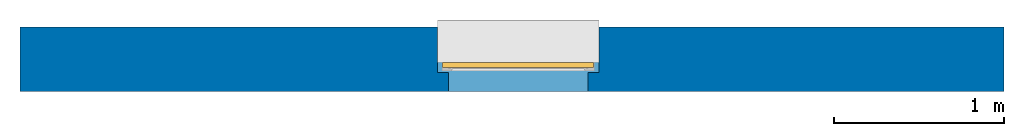
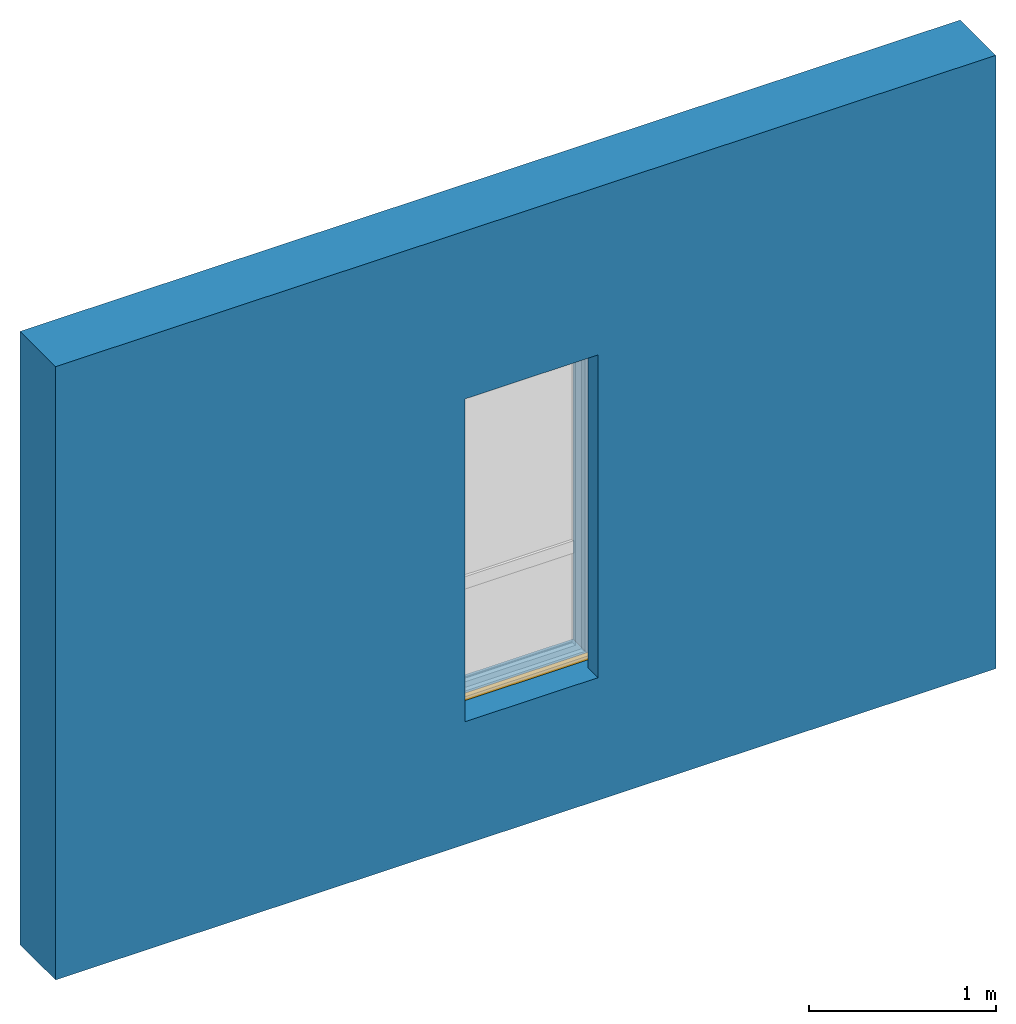
# One storey, part 1 of 3: 1 wall, 1 window, 1 opening.
"""IFC2X3 building model written with IfcOpenShell, lengths in millimetres."""

from ifc_helpers import new_model, entity, si_unit, converted_unit, derived_unit, direction, frame, frame_2d, origin, place, context, subcontext, project, spatial, rectangle, extrude, faceted_brep, source, transform, mapped, material, layer, layer_set, layer_usage, type_object, type_shapes, element, fill, save


model = new_model("IFC2X3")

# Units and contexts
model_context = context("Model", 3, precision=0.01, world=origin(), true_north=direction((6.12303176911189e-17, 1.0)))
context_of_model = context(None, 3, precision=0.01, world=origin(), true_north=direction((6.12303176911189e-17, 1.0)))
body_context = subcontext(model_context, "Body", "Model", "MODEL_VIEW")
ifc_project = project(units=[si_unit("LENGTHUNIT", "METRE", prefix="MILLI"), si_unit("AREAUNIT", "SQUARE_METRE"), si_unit("VOLUMEUNIT", "CUBIC_METRE"), converted_unit("PLANEANGLEUNIT", "DEGREE", entity("IfcRatioMeasure", 0.0174532925199433), si_unit("PLANEANGLEUNIT", "RADIAN"), dimensions=[0, 0, 0, 0, 0, 0, 0]), si_unit("MASSUNIT", "GRAM", prefix="KILO"), si_unit("TIMEUNIT", "SECOND"), si_unit("FREQUENCYUNIT", "HERTZ"), si_unit("THERMODYNAMICTEMPERATUREUNIT", "DEGREE_CELSIUS"), derived_unit("THERMALTRANSMITTANCEUNIT", [(si_unit("MASSUNIT", "GRAM", prefix="KILO"), 1), (si_unit("THERMODYNAMICTEMPERATUREUNIT", "KELVIN"), -1), (si_unit("TIMEUNIT", "SECOND"), -3)]), derived_unit("VOLUMETRICFLOWRATEUNIT", [(si_unit("LENGTHUNIT", "METRE"), 3), (si_unit("TIMEUNIT", "SECOND"), -1)]), si_unit("ELECTRICCURRENTUNIT", "AMPERE"), si_unit("ELECTRICVOLTAGEUNIT", "VOLT"), si_unit("POWERUNIT", "WATT"), si_unit("FORCEUNIT", "NEWTON", prefix="KILO"), si_unit("ILLUMINANCEUNIT", "LUX"), si_unit("LUMINOUSFLUXUNIT", "LUMEN"), si_unit("LUMINOUSINTENSITYUNIT", "CANDELA"), si_unit("PRESSUREUNIT", "PASCAL")], contexts=[model_context, context_of_model])

# Site, building, storey
site_placement = place(None, origin())
site = spatial("IfcSite", under=ifc_project, at=site_placement, CompositionType="ELEMENT")
building_placement = place(site_placement, origin())
building = spatial("IfcBuilding", under=site, at=building_placement, CompositionType="ELEMENT")
storey_placement = place(building_placement, origin())
storey = spatial("IfcBuildingStorey", under=building, at=storey_placement, CompositionType="ELEMENT", Elevation=0.0)

# Wall, opening, window
ifc_material_1 = material()
ifc_layer = layer(ifc_material_1, 380.0)
ifc_layer_set = layer_set([ifc_layer])
ifc_layer_usage = layer_usage(ifc_layer_set, "AXIS2", "NEGATIVE", 190.0)
wall_type = type_object("IfcWallType", PredefinedType="STANDARD", material=ifc_layer_set)
wall_placement = place(storey_placement, frame((-18279.8270290102, 12543.5585138251, 0.0)))
wall = element("IfcWallStandardCase", 1, at=wall_placement, inside=storey, type_object=wall_type, material=ifc_layer_usage, context=body_context, shape_type="SweptSolid", body=[
    extrude(rectangle(XDim=5800.0, YDim=380.0, at=frame_2d((2900.0, 0.0), x_axis=(-1.0, 0.0))), origin(), (0.0, 0.0, 1.0), 4000.0),
])
opening_placement = place(wall_placement, frame((2461.78748304286, -570.0, 800.0)))
opening = element("IfcOpeningElement", 2, at=opening_placement, cuts=wall, ObjectType="Opening", context=body_context, shape_type="Brep", body=[
    faceted_brep([(950.0, 1490.0, 2170.0), (950.0, 1490.0, 0.0), (0.0, 1490.0, 0.0), (0.0, 1490.0, 2170.0), (950.0, 490.0, 2170.0), (0.0, 490.0, 2170.0), (0.0, 490.0, 0.0), (65.0, 490.0, 0.0), (65.0, 490.0, 2105.0), (885.0, 490.0, 2105.0), (885.0, 490.0, 0.0), (950.0, 490.0, 0.0), (885.0, 0.0, 0.0), (65.0, 0.0, 0.0), (885.0, 0.0, 2105.0), (65.0, 0.0, 2105.0)], [[[0, 1, 2, 3]], [[4, 5, 6, 7, 8, 9, 10, 11]], [[3, 5, 4, 0]], [[2, 6, 5, 3]], [[1, 11, 10, 12, 13, 7, 6, 2]], [[0, 4, 11, 1]], [[14, 15, 13, 12]], [[14, 9, 8, 15]], [[15, 8, 7, 13]], [[12, 10, 9, 14]]]),
])
ifc_material_2 = material()
window_style = type_object("IfcWindowStyle", ConstructionType="NOTDEFINED", OperationType="NOTDEFINED", ParameterTakesPrecedence=False, Sizeable=False, material=ifc_material_2)
shared_shape = source(origin(), body_context, "Body", "SweptSolid", [
    extrude(rectangle(XDim=30.0, YDim=889.999999999999, at=frame_2d((1.77635683940025e-15, 0.0), x_axis=(1.0, 0.0))), frame((475.0, 955.0, 25.0), z_axis=(0.0, 0.0, 1.0), x_axis=(0.0, -1.0, 0.0)), (0.0, 0.0, 1.0), 25.000000000049),
])
type_shapes(window_style, [shared_shape])
window_placement = place(opening_placement, frame((950.0, 1490.0, 0.0), z_axis=(0.0, 0.0, 1.0), x_axis=(-1.0, 0.0, 0.0)))
window = element("IfcWindow", 3, at=window_placement, inside=storey, type_object=window_style, material=ifc_material_2, OverallHeight=2170.00000000006, OverallWidth=950.000000000006, context=body_context, shape_type="MappedRepresentation", body=[
    mapped(shared_shape, transform((0.0, 0.0, 0.0), scale=1.0)),
])
fill(opening, window)

save(model, "model.ifc")
